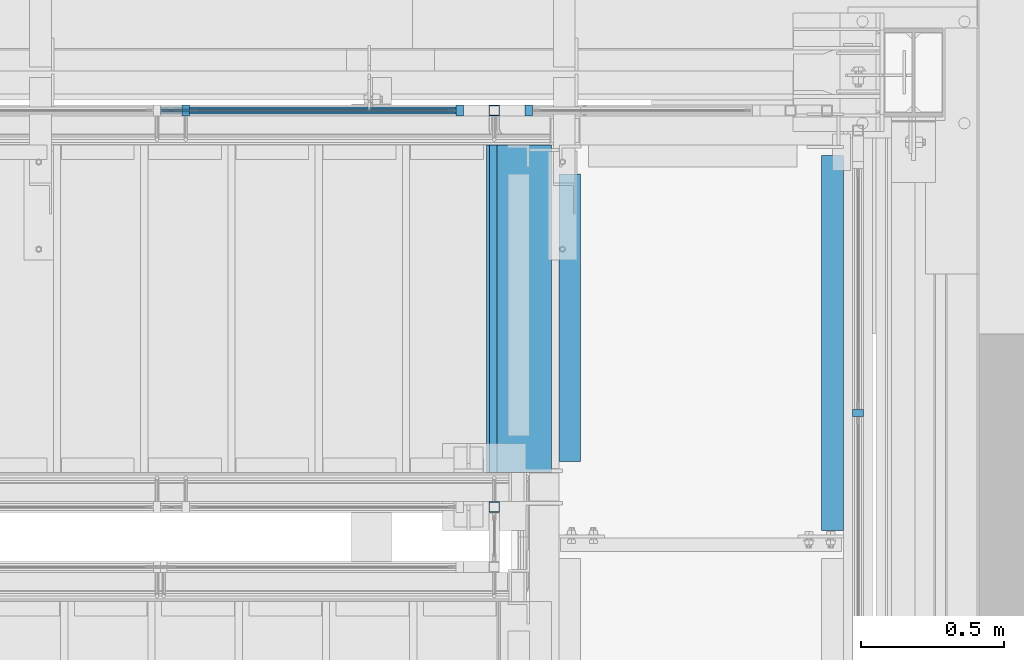
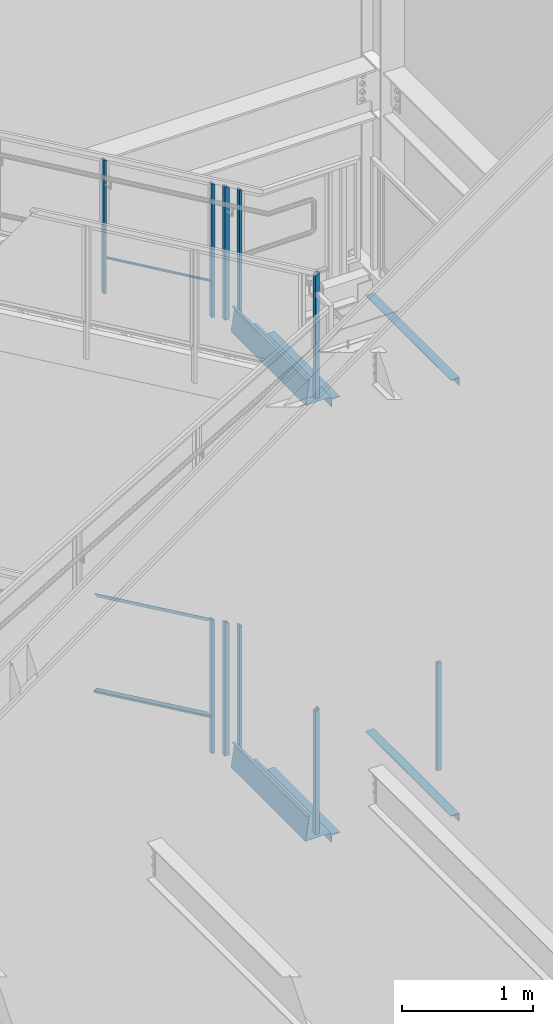
# One storey, part 799 of 1179: 12 members, 8 beams, 11 elements without a shape of their own.
"""IFC2X3 building model written with IfcOpenShell, lengths in millimetres."""

import ifcopenshell
import ifcopenshell.guid

model = None  # the IFC model being written
_history = None  # IfcOwnerHistory: only IFC2X3 demands one
_inside = {}  # id of a spatial element -> (the spatial element, [elements in it])
_under = {}  # id of a project, library or spatial element -> (it, [spatial elements below it])
_declared = {}  # id of a project -> (the project, [libraries it declares])
_typed = {}  # id of a type object -> (the type object, [elements of that type])
_made_of = {}  # id of a material, layer set ... -> (it, [elements and type objects made of it])


def new_model(schema):
    """Start an empty IFC model of exactly this schema.

    Asked for "IFC4X3", IfcOpenShell would pick the latest addendum, in which some entities
    have other attributes; the version numbers below select the first issue.
    IFC2X3 requires an IfcOwnerHistory on every rooted entity: one is made here for all.
    """
    global model, _history
    if schema == "IFC4X3":
        model = ifcopenshell.file(schema_version=(4, 3, 0, 0))
    else:
        model = ifcopenshell.file(schema=schema)
    _inside.clear()
    _under.clear()
    _declared.clear()
    _typed.clear()
    _made_of.clear()
    _history = None
    if model.schema == "IFC2X3":
        org = make("IfcOrganization", Name="unknown")
        user = make(
            "IfcPersonAndOrganization",
            ThePerson=make("IfcPerson", FamilyName="unknown"),
            TheOrganization=org,
        )
        app = make(
            "IfcApplication",
            ApplicationDeveloper=org,
            Version="unknown",
            ApplicationFullName="unknown",
            ApplicationIdentifier="unknown",
        )
        _history = make(
            "IfcOwnerHistory",
            OwningUser=user,
            OwningApplication=app,
            ChangeAction="ADDED",
            CreationDate=0,
        )
    return model


def make(cls, **values):
    """One entity of the class cls with the attributes given. An attribute that is None is left unset."""
    return model.create_entity(
        cls, **{name: value for name, value in values.items() if value is not None}
    )


def rooted(cls, **values):
    """An entity with a GlobalId (a new one), such as an element, a storey or a relation."""
    return make(cls, GlobalId=ifcopenshell.guid.new(), OwnerHistory=_history, **values)


def si_unit(unit_type, name, prefix=None):
    """IfcSIUnit, for example si_unit("LENGTHUNIT", "METRE", prefix="MILLI")."""
    return make("IfcSIUnit", UnitType=unit_type, Prefix=prefix, Name=name)


def assignment(units):
    """IfcUnitAssignment: the units of a project."""
    return None if units is None else make("IfcUnitAssignment", Units=units)


def point(xyz):
    """IfcCartesianPoint."""
    return None if xyz is None else make("IfcCartesianPoint", Coordinates=xyz)


def direction(xyz):
    """IfcDirection."""
    return None if xyz is None else make("IfcDirection", DirectionRatios=xyz)


def frame(location, z_axis=None, x_axis=None):
    """IfcAxis2Placement3D, a coordinate frame: its origin and axes. An axis left out is left unset."""
    return make(
        "IfcAxis2Placement3D",
        Location=point(location),
        Axis=direction(z_axis),
        RefDirection=direction(x_axis),
    )


def origin_with_axes():
    """The frame at (0, 0, 0) with the z axis (0, 0, 1) and the x axis (1, 0, 0) written out."""
    return frame((0.0, 0.0, 0.0), z_axis=(0.0, 0.0, 1.0), x_axis=(1.0, 0.0, 0.0))


def place(relative_to, where):
    """IfcLocalPlacement: puts the frame where relative to a parent placement (None: the world)."""
    return make(
        "IfcLocalPlacement", PlacementRelTo=relative_to, RelativePlacement=where
    )


def context(
    kind, dimensions, precision=None, world=None, true_north=None, identifier=None
):
    """IfcGeometricRepresentationContext, for example the 3D "Model" context."""
    return make(
        "IfcGeometricRepresentationContext",
        ContextIdentifier=identifier,
        ContextType=kind,
        CoordinateSpaceDimension=dimensions,
        Precision=precision,
        WorldCoordinateSystem=world,
        TrueNorth=true_north,
    )


def subcontext(parent, identifier, kind, view, scale=None):
    """IfcGeometricRepresentationSubContext, for example "Body" below "Model"."""
    return make(
        "IfcGeometricRepresentationSubContext",
        ContextIdentifier=identifier,
        ContextType=kind,
        ParentContext=parent,
        TargetScale=scale,
        TargetView=view,
    )


def project(units=None, contexts=None):
    """IfcProject with its units and contexts."""
    return rooted(
        "IfcProject",
        Name="project",
        RepresentationContexts=contexts,
        UnitsInContext=assignment(units),
    )


def spatial(cls, under=None, at=None, **own):
    """A site, building, storey or space (cls), placed at a placement, below another one or the project."""
    s = rooted(cls, ObjectPlacement=at, **own)
    if under is not None:
        _under.setdefault(under.id(), (under, []))[1].append(s)
    return s


def faces_of(points, faces, orient=None, outer=None):
    """IfcFace entities. A face is a list of loops; a loop is a list of indices into points, from 0.

    orient and outer hold one flag for each loop. By default every Orientation is true, the
    first loop of a face is its IfcFaceOuterBound and the others are IfcFaceBound.
    """
    made = []
    for i, loops in enumerate(faces):
        bounds = []
        for j, loop in enumerate(loops):
            is_outer = j == 0 if outer is None else outer[i][j]
            bounds.append(
                make(
                    "IfcFaceOuterBound" if is_outer else "IfcFaceBound",
                    Bound=make("IfcPolyLoop", Polygon=[points[k] for k in loop]),
                    Orientation=True if orient is None else orient[i][j],
                )
            )
        made.append(make("IfcFace", Bounds=bounds))
    return made


def faceted_brep(points, faces, orient=None, outer=None, voids=None):
    """IfcFacetedBrep: a solid bounded by flat faces; with voids (closed shells), ...WithVoids."""
    shared = [point(p) for p in points]
    hull = make("IfcClosedShell", CfsFaces=faces_of(shared, faces, orient, outer))
    if voids is None:
        return make("IfcFacetedBrep", Outer=hull)
    return make(
        "IfcFacetedBrepWithVoids",
        Outer=hull,
        Voids=[
            make(cls, CfsFaces=faces_of(shared, fs, o, b)) for cls, fs, o, b in voids
        ],
    )


def shape(context_of_items, identifier, shape_type, items):
    """IfcShapeRepresentation: the items that make up one representation, for example the "Body"."""
    return make(
        "IfcShapeRepresentation",
        ContextOfItems=context_of_items,
        RepresentationIdentifier=identifier,
        RepresentationType=shape_type,
        Items=items,
    )


def material(Name=None, Category=None):
    """IfcMaterial."""
    return make("IfcMaterial", Name=Name, Category=Category)


def made_of(thing, what):
    """Note that an element or type object is made of a material, layer set ...; save() writes the relation."""
    if what is not None:
        _made_of.setdefault(what.id(), (what, []))[1].append(thing)
    return thing


def type_object(cls, material=None, **own):
    """A type object (cls), such as IfcWallType, which elements share."""
    return made_of(rooted(cls, **own), material)


def element(
    cls,
    number,
    at=None,
    inside=None,
    cuts=None,
    type_object=None,
    material=None,
    context=None,
    identifier="Body",
    shape_type=None,
    held_by="IfcProductDefinitionShape",
    body=None,
    shapes=None,
    **own,
):
    """One element of the class cls, such as IfcWall. Its Tag is "e" and its number.

    at: its placement. inside: the storey or other place that contains it. cuts: it is an
    opening in that element (IfcRelVoidsElement). A single representation is given by context,
    identifier, shape_type and body (its items); several are given by shapes. held_by: the class
    of the entity that holds the representations. save() writes the other relations.
    """
    e = rooted(cls, Tag="e%d" % number, ObjectPlacement=at, **own)
    if body is not None:
        shapes = [shape(context, identifier, shape_type, body)]
    if shapes is not None:
        e.Representation = make(held_by, Representations=shapes)
    if inside is not None:
        _inside.setdefault(inside.id(), (inside, []))[1].append(e)
    if cuts is not None:
        rooted(
            "IfcRelVoidsElement", RelatingBuildingElement=cuts, RelatedOpeningElement=e
        )
    if type_object is not None:
        _typed.setdefault(type_object.id(), (type_object, []))[1].append(e)
    return made_of(e, material)


def aggregate(whole, parts):
    """IfcRelAggregates: a whole, such as a stair, and the parts it consists of."""
    return rooted("IfcRelAggregates", RelatingObject=whole, RelatedObjects=parts)


def save(model, path):
    """Write the relations noted so far, then the file.

    IfcRelAggregates (storeys below a building ...), IfcRelContainedInSpatialStructure (elements
    in a storey), IfcRelDefinesByType, IfcRelAssociatesMaterial and IfcRelDeclares: one each for
    every whole, place, type object, material and project.
    """
    for whole, parts in _under.values():
        aggregate(whole, parts)
    for where, things in _inside.values():
        rooted(
            "IfcRelContainedInSpatialStructure",
            RelatedElements=things,
            RelatingStructure=where,
        )
    for kind, things in _typed.values():
        rooted("IfcRelDefinesByType", RelatedObjects=things, RelatingType=kind)
    for what, things in _made_of.values():
        rooted("IfcRelAssociatesMaterial", RelatedObjects=things, RelatingMaterial=what)
    for by, libraries in _declared.values():
        rooted("IfcRelDeclares", RelatingContext=by, RelatedDefinitions=libraries)
    model.write(path)


model = new_model("IFC2X3")

# Units and contexts
model_context = context("Model", 3, precision=1e-05, world=origin_with_axes())
body_context = subcontext(model_context, "Body", "Model", "MODEL_VIEW")
ifc_project = project(units=[si_unit("LENGTHUNIT", "METRE", prefix="MILLI"), si_unit("AREAUNIT", "SQUARE_METRE"), si_unit("VOLUMEUNIT", "CUBIC_METRE"), si_unit("MASSUNIT", "GRAM", prefix="KILO"), si_unit("TIMEUNIT", "SECOND"), si_unit("PLANEANGLEUNIT", "RADIAN"), si_unit("SOLIDANGLEUNIT", "STERADIAN"), si_unit("THERMODYNAMICTEMPERATUREUNIT", "DEGREE_CELSIUS"), si_unit("LUMINOUSINTENSITYUNIT", "LUMEN")], contexts=[model_context])

# Site, building, storey
site_placement = place(None, origin_with_axes())
site = spatial("IfcSite", under=ifc_project, at=site_placement, CompositionType="ELEMENT")
building_placement = place(site_placement, origin_with_axes())
building = spatial("IfcBuilding", under=site, at=building_placement, Name="Undefined", CompositionType="ELEMENT")
storey_placement = place(building_placement, origin_with_axes())
storey = spatial("IfcBuildingStorey", under=building, at=storey_placement, Name="Undefined", CompositionType="ELEMENT", Elevation=0.0)

# Assembly, members
assembly_1_placement = place(storey_placement, origin_with_axes())
assembly_1 = element("IfcElementAssembly", 1, at=assembly_1_placement, inside=storey, Name="GUARDRAIL", AssemblyPlace="NOTDEFINED", PredefinedType="RIGID_FRAME")
ifc_material_1 = material(Name="STEEL/A36")
member_type_1 = type_object("IfcMemberType", PredefinedType="NOTDEFINED")
member_1_placement = place(assembly_1_placement, frame((22964.7750009048, 41065.449999238, 6098.38737109697), z_axis=(0.0, -1.0, 0.0), x_axis=(0.0, 0.0, 1.0)))
member_1 = element("IfcMember", 2, at=member_1_placement, type_object=member_type_1, material=ifc_material_1, Name="POST", context=body_context, shape_type="Brep", body=[
    faceted_brep([(0.0, 12.7000000000007, -19.0500000000029), (0.0, 12.7000000000007, 19.0500000000029), (1257.9937907086, 12.7000000000007, 19.0500000000029), (1257.9937907086, 12.7000000000007, -19.0500000000029), (0.0, -12.7000000000007, 19.0500000000029), (1243.17712405909, -12.7000000000007, 19.0500000000029), (0.0, -12.7000000000007, -19.0500000000029), (1243.17712405909, -12.7000000000007, -19.0500000000029)], [[[0, 1, 2, 3]], [[1, 4, 5, 2]], [[4, 6, 7, 5]], [[6, 0, 3, 7]], [[5, 7, 3, 2]], [[6, 4, 1, 0]]]),
])
member_2_placement = place(assembly_1_placement, frame((22723.4750009048, 41065.449999238, 6239.1457045467), z_axis=(0.0, -1.0, 0.0), x_axis=(0.0, 0.0, 1.0)))
member_2 = element("IfcMember", 3, at=member_2_placement, type_object=member_type_1, material=ifc_material_1, Name="POST", context=body_context, shape_type="Brep", body=[
    faceted_brep([(0.0, 12.7000000000007, -19.0500000000029), (0.0, 12.7000000000007, 19.0500000000029), (1257.9937907086, 12.7000000000007, 19.0500000000029), (1257.9937907086, 12.7000000000007, -19.0500000000029), (0.0, -12.7000000000007, 19.0500000000029), (1243.17712405909, -12.7000000000007, 19.0500000000029), (0.0, -12.7000000000007, -19.0500000000029), (1243.17712405909, -12.7000000000007, -19.0500000000029)], [[[0, 1, 2, 3]], [[1, 4, 5, 2]], [[4, 6, 7, 5]], [[6, 0, 3, 7]], [[5, 7, 3, 2]], [[6, 4, 1, 0]]]),
])
member_3_placement = place(assembly_1_placement, frame((21766.7416677555, 41065.449999238, 6797.2401493453), z_axis=(0.0, -1.0, 0.0), x_axis=(0.0, 0.0, 1.0)))
member_3 = element("IfcMember", 4, at=member_3_placement, type_object=member_type_1, material=ifc_material_1, Name="POST", context=body_context, shape_type="Brep", body=[
    faceted_brep([(0.0, 12.7000000000007, -19.0500000000029), (0.0, 12.7000000000007, 19.0500000000029), (1257.9937907086, 12.7000000000007, 19.0500000000029), (1257.9937907086, 12.7000000000007, -19.0500000000029), (0.0, -12.7000000000007, 19.0500000000029), (1243.17712405909, -12.7000000000007, 19.0500000000029), (0.0, -12.7000000000007, -19.0500000000029), (1243.17712405909, -12.7000000000007, -19.0500000000029)], [[[0, 1, 2, 3]], [[1, 4, 5, 2]], [[4, 6, 7, 5]], [[6, 0, 3, 7]], [[5, 7, 3, 2]], [[6, 4, 1, 0]]]),
])

assembly_2_placement = place(storey_placement, origin_with_axes())
assembly_2 = element("IfcElementAssembly", 5, at=assembly_2_placement, inside=storey, Name="GUARDRAIL", AssemblyPlace="NOTDEFINED", PredefinedType="RIGID_FRAME")
member_4_placement = place(assembly_2_placement, frame((22964.7748872972, 41065.4499993604, 2024.409589174), z_axis=(0.0, -1.0, 0.0), x_axis=(0.0, 0.0, 1.0)))
member_4 = element("IfcMember", 6, at=member_4_placement, type_object=member_type_1, material=ifc_material_1, Name="POST", context=body_context, shape_type="Brep", body=[
    faceted_brep([(0.0, 12.7000000000007, -19.0500000000029), (0.0, 12.7000000000007, 19.0500000000029), (1257.59245944594, 12.7000000000007, 19.0500000000029), (1257.59245944594, 12.7000000000007, -19.0500000000029), (0.0, -12.7000000000007, 19.0500000000029), (1242.88603583053, -12.7000000000007, 19.0500000000029), (0.0, -12.7000000000007, -19.0500000000029), (1242.88603583053, -12.7000000000007, -19.0500000000029)], [[[0, 1, 2, 3]], [[1, 4, 5, 2]], [[4, 6, 7, 5]], [[6, 0, 3, 7]], [[5, 7, 3, 2]], [[6, 4, 1, 0]]]),
])
member_5_placement = place(assembly_2_placement, frame((22723.4748880622, 41065.4499993604, 2164.12061307754), z_axis=(0.0, -1.0, 0.0), x_axis=(0.0, 0.0, 1.0)))
member_5 = element("IfcMember", 7, at=member_5_placement, type_object=member_type_1, material=ifc_material_1, Name="POST", context=body_context, shape_type="Brep", body=[
    faceted_brep([(0.0, 12.7000000000007, -19.0500000000029), (0.0, 12.7000000000007, 19.0500000000029), (1257.59245944594, 12.7000000000007, 19.0500000000029), (1257.59245944594, 12.7000000000007, -19.0500000000029), (0.0, -12.7000000000007, 19.0500000000029), (1242.88603583053, -12.7000000000007, 19.0500000000029), (0.0, -12.7000000000007, -19.0500000000029), (1242.88603583053, -12.7000000000007, -19.0500000000029)], [[[0, 1, 2, 3]], [[1, 4, 5, 2]], [[4, 6, 7, 5]], [[6, 0, 3, 7]], [[5, 7, 3, 2]], [[6, 4, 1, 0]]]),
])

# Assembly, member
assembly_3_placement = place(storey_placement, origin_with_axes())
assembly_3 = element("IfcElementAssembly", 8, at=assembly_3_placement, inside=storey, Name="GUARDRAIL", AssemblyPlace="NOTDEFINED", PredefinedType="RIGID_FRAME")
member_6_placement = place(assembly_3_placement, frame((24114.1250004143, 40009.2333333341, 2155.82499903482), z_axis=(-1.0, 0.0, 0.0), x_axis=(0.0, 0.0, 1.0)))
member_6 = element("IfcMember", 9, at=member_6_placement, type_object=member_type_1, material=ifc_material_1, Name="POST", context=body_context, shape_type="Brep", body=[
    faceted_brep([(0.0, 12.7000000000007, -19.0500000000029), (0.0, 12.7000000000007, 19.0500000000029), (1009.65000040151, 12.6999999999971, 19.0499999999993), (1009.65000040151, 12.6999999999971, -19.0499999999993), (0.0, -12.7000000000007, 19.0500000000029), (1009.65000040151, -12.6999999999971, 19.0499999999993), (0.0, -12.7000000000007, -19.0500000000029), (1009.65000040151, -12.6999999999971, -19.0499999999993)], [[[0, 1, 2, 3]], [[1, 4, 5, 2]], [[4, 6, 7, 5]], [[6, 0, 3, 7]], [[5, 7, 3, 2]], [[6, 4, 1, 0]]]),
])
aggregate(assembly_3, [member_6])

# Beam
ifc_material_2 = material(Name="STEEL/BUY-OUT")
beam_type_1 = type_object("IfcBeamType", PredefinedType="NOTDEFINED")
beam_1_placement = place(assembly_2_placement, frame((22207.4122472657, 41062.2751647691, 2831.43122798005), z_axis=(0.86540914081268, 0.0, -0.501065882891521), x_axis=(-0.501065882891527, 0.0, -0.865409140812677)))
beam_1 = element("IfcBeam", 10, at=beam_1_placement, type_object=beam_type_1, material=ifc_material_2, Name="U-EDGE", context=body_context, shape_type="Brep", body=[
    faceted_brep([(-2.17914930544794e-09, 1.58750000000146, -579.8750616161), (-2.17914930544794e-09, -1.58750000000146, -579.8750616161), (2.06819095183164e-09, -1.58750000000146, 550.462303003866), (2.06819095183164e-09, 1.58750000000146, 550.462303003866), (22.2250000220702, 1.58750000000146, -592.688577145202), (22.225000051898, 1.58750000000146, 589.01191290709), (22.225000034794, 4.76249998386629, -592.688577152541), (22.2250000392505, 4.7625000160333, 589.011912885151), (7.50696926843375e-08, 4.76249998754065, -579.875061660634), (7.28450686438009e-08, 4.7625000118278, 550.462303126626), (7.50696926843375e-08, 7.93749998753628, -579.875061660634), (7.28450686438009e-08, 7.93750001182343, 550.462303126626), (25.4000000347896, 7.93749998381099, -594.518999999977), (25.4000000343149, 7.9375, 594.519), (25.4000000220258, -1.58750000000146, -594.518999999807), (25.4000000343149, -1.58750000000146, 594.519)], [[[0, 1, 2, 3]], [[4, 0, 3, 5]], [[6, 4, 5, 7]], [[8, 6, 7, 9]], [[10, 8, 9, 11]], [[12, 10, 11, 13]], [[14, 12, 13, 15]], [[11, 9, 7, 5, 3, 2, 15, 13]], [[1, 14, 15, 2]], [[0, 4, 6, 8, 10, 12, 14, 1]]]),
])

beam_2_placement = place(assembly_2_placement, frame((22181.9581376491, 41062.2751647691, 3697.10650203671), z_axis=(0.86540914081268, 0.0, -0.501065882891521), x_axis=(0.501065882891522, 0.0, 0.865409140812679)))
beam_2 = element("IfcBeam", 11, at=beam_2_placement, type_object=beam_type_1, material=ifc_material_2, Name="U-EDGE", context=body_context, shape_type="Brep", body=[
    faceted_brep([(-5.08043740410358e-09, -4.76250001176231, -550.462297073285), (-5.08043740410358e-09, -7.93750001176522, -550.462297073285), (2.06819095183164e-09, -7.93749998760177, 579.875144306196), (2.06819095183164e-09, -4.76249998760613, 579.875144306196), (22.2249999989635, -4.76250001590233, -589.011912123857), (22.2249999997566, -4.76249998399726, 592.68851804268), (22.2250000115582, -1.58750000000146, -589.011912145696), (22.2249999870892, -1.58750000000146, 592.68851803538), (-3.47426976077259e-10, -1.58750000000146, -550.462297081494), (3.69254848919809e-10, -1.58750000000146, 579.875144305217), (-3.47426976077259e-10, 1.58750000000146, -550.462297081494), (3.69254848919809e-10, 1.58750000000146, 579.875144305217), (25.4000001784334, 1.58750000000146, -594.51900000087), (25.3999999489688, 1.58750000000146, 594.519), (25.4000002532193, -7.93749990531796, -594.51900000187), (25.3999999489688, -7.9375, 594.519)], [[[0, 1, 2, 3]], [[4, 0, 3, 5]], [[6, 4, 5, 7]], [[8, 6, 7, 9]], [[10, 8, 9, 11]], [[12, 10, 11, 13]], [[14, 12, 13, 15]], [[11, 9, 7, 5, 3, 2, 15, 13]], [[1, 14, 15, 2]], [[0, 4, 6, 8, 10, 12, 14, 1]]]),
])

# Member
ifc_material_3 = material()
member_type_2 = type_object("IfcMemberType", Name="HSS1-1/2X1-1/2X1/8", PredefinedType="NOTDEFINED")
member_7_placement = place(assembly_1_placement, frame((22844.1250009048, 41065.449999238, 6168.76653782184), z_axis=(-1.0, 0.0, 0.0), x_axis=(0.0, 0.0, 1.0)))
member_7 = element("IfcMember", 12, at=member_7_placement, type_object=member_type_2, material=ifc_material_3, Name="POST", ObjectType="HSS1-1/2X1-1/2X1/8", context=body_context, shape_type="Brep", body=[
    faceted_brep([(6.35000000000014, 15.874999282998, -15.8749992830017), (6.35000000000014, -15.874999282998, -15.8749992830017), (1241.32504350118, -15.874999282998, -15.8749992830017), (1241.32504350118, 15.874999282998, -15.8749992830017), (6.35000000000014, -15.874999282998, 15.8749992830017), (1259.84587597657, -15.874999282998, 15.8749992830017), (6.35000000000014, 15.874999282998, 15.8749992830017), (1259.84587597657, 15.874999282998, 15.8749992830017), (6.35000000000014, 19.0499992350015, -19.0499992350015), (6.35000000000014, 19.0499992350015, 19.0499992350015), (1261.69795927976, 19.0499992350015, 19.0499992350015), (1239.47296019799, 19.0499992350015, -19.0499992350015), (6.35000000000014, -19.0499992350015, 19.0499992350015), (1261.69795927976, -19.0499992350015, 19.0499992350015), (6.35000000000014, -19.0499992350015, -19.0499992350015), (1239.47296019799, -19.0499992350015, -19.0499992350015)], [[[0, 1, 2, 3]], [[1, 4, 5, 2]], [[4, 6, 7, 5]], [[6, 0, 3, 7]], [[8, 9, 10, 11]], [[9, 12, 13, 10]], [[12, 14, 15, 13]], [[14, 8, 11, 15]], [[13, 15, 11, 10], [5, 7, 3, 2]], [[14, 12, 9, 8], [6, 4, 1, 0]]]),
])

member_8_placement = place(assembly_2_placement, frame((22844.1248872972, 41065.4499993604, 2094.26510134723), z_axis=(-1.0, 0.0, 0.0), x_axis=(0.0, 0.0, 1.0)))
member_8 = element("IfcMember", 13, at=member_8_placement, type_object=member_type_2, material=ifc_material_3, Name="POST", ObjectType="HSS1-1/2X1-1/2X1/8", context=body_context, shape_type="Brep", body=[
    faceted_brep([(6.35000000000014, 15.874999282998, -15.8749992830017), (6.35000000000014, -15.874999282998, -15.8749992830017), (1241.04773329657, -15.874999282998, -15.8749992830017), (1241.04773329657, 15.874999282998, -15.8749992830017), (6.35000000000014, -15.874999282998, 15.8749992830017), (1259.43076198557, -15.874999282998, 15.8749992830017), (6.35000000000014, 15.874999282998, 15.8749992830017), (1259.43076198557, 15.874999282998, 15.8749992830017), (6.35000000000014, 19.0499992350015, -19.0499992350015), (6.35000000000014, 19.0499992350015, 19.0499992350015), (1261.2690649097, 19.0499992350015, 19.0499992350015), (1239.20943037244, 19.0499992350015, -19.0499992350015), (6.35000000000014, -19.0499992350015, 19.0499992350015), (1261.2690649097, -19.0499992350015, 19.0499992350015), (6.35000000000014, -19.0499992350015, -19.0499992350015), (1239.20943037244, -19.0499992350015, -19.0499992350015)], [[[0, 1, 2, 3]], [[1, 4, 5, 2]], [[4, 6, 7, 5]], [[6, 0, 3, 7]], [[8, 9, 10, 11]], [[9, 12, 13, 10]], [[12, 14, 15, 13]], [[14, 8, 11, 15]], [[13, 15, 11, 10], [5, 7, 3, 2]], [[14, 12, 9, 8], [6, 4, 1, 0]]]),
])

# Assembly, member
assembly_4_placement = place(storey_placement, origin_with_axes())
assembly_4 = element("IfcElementAssembly", 14, at=assembly_4_placement, inside=storey, Name="GUARDRAIL", AssemblyPlace="NOTDEFINED", PredefinedType="RIGID_FRAME")
member_9_placement = place(assembly_4_placement, frame((22844.1250009048, 39681.1500007796, 6275.74561220699), z_axis=(-1.0, 0.0, 0.0), x_axis=(0.0, 0.0, 1.0)))
member_9 = element("IfcMember", 15, at=member_9_placement, type_object=member_type_2, material=ifc_material_3, Name="POST", ObjectType="HSS1-1/2X1-1/2X1/8", context=body_context, shape_type="Brep", body=[
    faceted_brep([(6.35000000000014, 15.874999282998, -15.8749992830017), (6.35000000000014, -15.874999282998, -15.8749992830017), (1174.77876794096, -15.874999282998, -15.8749992830017), (1174.77876794096, 15.874999282998, -15.8749992830017), (6.35000000000014, -15.874999282998, 15.8749992830017), (1156.54251067731, -15.874999282998, 15.8749992830017), (6.35000000000014, 15.874999282998, 15.8749992830017), (1156.54251067731, 15.874999282998, 15.8749992830017), (6.35000000000014, 19.0499992350015, -19.0499992350015), (6.35000000000014, 19.0499992350015, 19.0499992350015), (1154.71888489615, 19.0499992350015, 19.0499992350015), (1176.60239372212, 19.0499992350015, -19.0499992350015), (6.35000000000014, -19.0499992350015, 19.0499992350015), (1154.71888489615, -19.0499992350015, 19.0499992350015), (6.35000000000014, -19.0499992350015, -19.0499992350015), (1176.60239372212, -19.0499992350015, -19.0499992350015)], [[[0, 1, 2, 3]], [[1, 4, 5, 2]], [[4, 6, 7, 5]], [[6, 0, 3, 7]], [[8, 9, 10, 11]], [[9, 12, 13, 10]], [[12, 14, 15, 13]], [[14, 8, 11, 15]], [[13, 15, 11, 10], [5, 7, 3, 2]], [[14, 12, 9, 8], [6, 4, 1, 0]]]),
])
aggregate(assembly_4, [member_9])

assembly_5_placement = place(storey_placement, origin_with_axes())
assembly_5 = element("IfcElementAssembly", 16, at=assembly_5_placement, inside=storey, Name="GUARDRAIL", AssemblyPlace="NOTDEFINED", PredefinedType="RIGID_FRAME")
member_10_placement = place(assembly_5_placement, frame((22844.1248872972, 39681.150000778, 2202.22061306289), z_axis=(-1.0, 0.0, 0.0), x_axis=(0.0, 0.0, 1.0)))
member_10 = element("IfcMember", 17, at=member_10_placement, type_object=member_type_2, material=ifc_material_3, Name="POST", ObjectType="HSS1-1/2X1-1/2X1/8", context=body_context, shape_type="Brep", body=[
    faceted_brep([(6.35000000000014, 15.874999282998, -15.8749992830017), (6.35000000000014, -15.874999282998, -15.8749992830017), (1173.44885345168, -15.874999282998, -15.8749992830017), (1173.44885345168, 15.874999282998, -15.8749992830017), (6.35000000000014, -15.874999282998, 15.8749992830017), (1155.14403466819, -15.874999282998, 15.8749992830017), (6.35000000000014, 15.874999282998, 15.8749992830017), (1155.14403466819, 15.874999282998, 15.8749992830017), (6.35000000000014, 19.0499992350015, -19.0499992350015), (6.35000000000014, 19.0499992350015, 19.0499992350015), (1153.31355273484, 19.0499992350015, 19.0499992350015), (1175.27933538503, 19.0499992350015, -19.0499992350015), (6.35000000000014, -19.0499992350015, 19.0499992350015), (1153.31355273484, -19.0499992350015, 19.0499992350015), (6.35000000000014, -19.0499992350015, -19.0499992350015), (1175.27933538503, -19.0499992350015, -19.0499992350015)], [[[0, 1, 2, 3]], [[1, 4, 5, 2]], [[4, 6, 7, 5]], [[6, 0, 3, 7]], [[8, 9, 10, 11]], [[9, 12, 13, 10]], [[12, 14, 15, 13]], [[14, 8, 11, 15]], [[13, 15, 11, 10], [5, 7, 3, 2]], [[14, 12, 9, 8], [6, 4, 1, 0]]]),
])
aggregate(assembly_5, [member_10])

# Member
member_type_3 = type_object("IfcMemberType", PredefinedType="NOTDEFINED")
member_11_placement = place(assembly_1_placement, frame((21766.7416677555, 41065.4499992401, 7128.05397191716), z_axis=(0.0, -1.0, 0.0), x_axis=(0.863778851027978, 0.0, -0.503871111016285)))
member_11 = element("IfcMember", 18, at=member_11_placement, type_object=member_type_3, material=ifc_material_1, Name="BOTTOM_RAIL", context=body_context, shape_type="Brep", body=[
    faceted_brep([(10.9986698874163, 6.34999999999854, -12.6999999999971), (10.9986698874163, 6.34999999999854, 12.6999999999971), (1089.20668431148, 6.35000000024229, 12.6999999999971), (1089.20668431148, 6.35000000024229, -12.6999999999971), (18.4070032121654, -6.34999999999127, 12.6999999999971), (1096.61501763624, -6.34999999974752, 12.6999999999971), (18.4070032121654, -6.34999999999127, -12.6999999999971), (1096.61501763624, -6.34999999974752, -12.6999999999971)], [[[0, 1, 2, 3]], [[1, 4, 5, 2]], [[4, 6, 7, 5]], [[6, 0, 3, 7]], [[5, 7, 3, 2]], [[6, 4, 1, 0]]]),
])

aggregate(assembly_1, [member_1, member_2, member_11, member_7, member_3])

member_12_placement = place(assembly_2_placement, frame((21666.1999246046, 41065.4499993604, 3106.46611713066), z_axis=(0.0, -1.0, 0.0), x_axis=(0.86540914081268, 0.0, -0.501065882891521)))
member_12 = element("IfcMember", 19, at=member_12_placement, type_object=member_type_3, material=ifc_material_1, Name="BOTTOM_RAIL", context=body_context, shape_type="Brep", body=[
    faceted_brep([(10.998533752896, 6.34999999999854, -12.6999999999971), (10.998533752896, 6.34999999999854, 12.6999999999971), (1203.35358848741, 6.35000000053878, 12.6999999999971), (1203.35358848741, 6.35000000053878, -12.6999999999971), (18.3517455606161, -6.34999999998945, 12.6999999999971), (1210.70680029513, -6.34999999944921, 12.6999999999971), (18.3517455606161, -6.34999999998945, -12.6999999999971), (1210.70680029513, -6.34999999944921, -12.6999999999971)], [[[0, 1, 2, 3]], [[1, 4, 5, 2]], [[4, 6, 7, 5]], [[6, 0, 3, 7]], [[5, 7, 3, 2]], [[6, 4, 1, 0]]]),
])

aggregate(assembly_2, [member_4, beam_1, beam_2, member_5, member_12, member_8])

# Assembly, beam
assembly_6_placement = place(storey_placement, origin_with_axes())
assembly_6 = element("IfcElementAssembly", 20, at=assembly_6_placement, inside=storey, Name="BEAM", AssemblyPlace="NOTDEFINED", PredefinedType="RIGID_FRAME")
beam_type_2 = type_object("IfcBeamType", Name="L3X3X1/4", PredefinedType="NOTDEFINED")
beam_3_placement = place(assembly_6_placement, frame((24025.225, 39598.996875, 6051.55), z_axis=(0.0, 0.0, -1.0), x_axis=(0.0, 1.0, 0.0)))
beam_3 = element("IfcBeam", 21, at=beam_3_placement, type_object=beam_type_2, material=ifc_material_1, Name="ANGLE", ObjectType="L3X3X1/4", context=body_context, shape_type="Brep", body=[
    faceted_brep([(0.0, 38.0999999999985, -38.0999999999999), (0.0, 38.0999999999985, 38.0999999999999), (1309.29062501167, 38.0999999999985, 38.1000000000004), (1309.29062501167, 38.0999999999985, -38.1000000000004), (0.0, 31.75, 38.1000000000004), (1309.29062501167, 31.75, 38.1000000000004), (0.0, 31.75, -31.75), (1309.29062501167, 31.75, -31.75), (0.0, -38.0999999999985, -31.75), (1309.29062501167, -38.0999999999985, -31.75), (0.0, -38.0999999999985, -38.0999999999999), (1309.29062501167, -38.0999999999985, -38.1000000000004)], [[[0, 1, 2, 3]], [[1, 4, 5, 2]], [[4, 6, 7, 5]], [[6, 8, 9, 7]], [[8, 10, 11, 9]], [[10, 0, 3, 11]], [[5, 7, 9, 11, 3, 2]], [[10, 8, 6, 4, 1, 0]]]),
])
aggregate(assembly_6, [beam_3])

assembly_7_placement = place(storey_placement, origin_with_axes())
assembly_7 = element("IfcElementAssembly", 22, at=assembly_7_placement, inside=storey, Name="BEAM", AssemblyPlace="NOTDEFINED", PredefinedType="RIGID_FRAME")
beam_4_placement = place(assembly_7_placement, frame((23107.6499999238, 39839.9000000055, 6051.55), z_axis=(1.0, 0.0, 0.0), x_axis=(0.0, 1.0, 0.0)))
beam_4 = element("IfcBeam", 23, at=beam_4_placement, type_object=beam_type_2, material=ifc_material_1, Name="ANGLE", ObjectType="L3X3X1/4", context=body_context, shape_type="Brep", body=[
    faceted_brep([(0.0, 38.0999999999985, -38.0999999999999), (0.0, 38.0999999999985, 38.0999999999999), (1003.29999999383, 38.1000000000004, 38.0999999999985), (1003.29999999383, 38.1000000000004, -38.0999999999985), (0.0, 31.75, 38.1000000000004), (1003.29999999383, 31.75, 38.0999999999985), (0.0, 31.75, -31.75), (1003.29999999383, 31.75, -31.75), (0.0, -38.0999999999985, -31.75), (1003.29999999383, -38.1000000000004, -31.75), (0.0, -38.0999999999985, -38.0999999999999), (1003.29999999383, -38.1000000000004, -38.0999999999985)], [[[0, 1, 2, 3]], [[1, 4, 5, 2]], [[4, 6, 7, 5]], [[6, 8, 9, 7]], [[8, 10, 11, 9]], [[10, 0, 3, 11]], [[5, 7, 9, 11, 3, 2]], [[10, 8, 6, 4, 1, 0]]]),
])
aggregate(assembly_7, [beam_4])

assembly_8_placement = place(storey_placement, origin_with_axes())
assembly_8 = element("IfcElementAssembly", 24, at=assembly_8_placement, inside=storey, Name="BEAM", AssemblyPlace="NOTDEFINED", PredefinedType="RIGID_FRAME")
beam_5_placement = place(assembly_8_placement, frame((24025.2250004143, 39598.996875, 1978.025), z_axis=(0.0, 0.0, -1.0), x_axis=(0.0, 1.0, 0.0)))
beam_5 = element("IfcBeam", 25, at=beam_5_placement, type_object=beam_type_2, material=ifc_material_1, Name="ANGLE", ObjectType="L3X3X1/4", context=body_context, shape_type="Brep", body=[
    faceted_brep([(0.0, 38.0999999999985, -38.0999999999999), (0.0, 38.0999999999985, 38.0999999999999), (1309.29062501167, 38.0999999999985, 38.1000000000004), (1309.29062501167, 38.0999999999985, -38.1000000000004), (0.0, 31.75, 38.1000000000004), (1309.29062501167, 31.75, 38.1000000000004), (0.0, 31.75, -31.75), (1309.29062501167, 31.75, -31.75), (0.0, -38.0999999999985, -31.75), (1309.29062501167, -38.0999999999985, -31.75), (0.0, -38.0999999999985, -38.0999999999999), (1309.29062501167, -38.0999999999985, -38.1000000000004)], [[[0, 1, 2, 3]], [[1, 4, 5, 2]], [[4, 6, 7, 5]], [[6, 8, 9, 7]], [[8, 10, 11, 9]], [[10, 0, 3, 11]], [[5, 7, 9, 11, 3, 2]], [[10, 8, 6, 4, 1, 0]]]),
])
aggregate(assembly_8, [beam_5])

assembly_9_placement = place(storey_placement, origin_with_axes())
assembly_9 = element("IfcElementAssembly", 26, at=assembly_9_placement, inside=storey, Name="BEAM", AssemblyPlace="NOTDEFINED", PredefinedType="RIGID_FRAME")
beam_6_placement = place(assembly_9_placement, frame((23107.6500003381, 39839.9000000405, 1978.025), z_axis=(1.0, 0.0, 0.0), x_axis=(0.0, 1.0, 0.0)))
beam_6 = element("IfcBeam", 27, at=beam_6_placement, type_object=beam_type_2, material=ifc_material_1, Name="ANGLE", ObjectType="L3X3X1/4", context=body_context, shape_type="Brep", body=[
    faceted_brep([(0.0, 38.0999999999985, -38.0999999999999), (0.0, 38.0999999999985, 38.0999999999999), (1003.29999999383, 38.1000000000004, 38.0999999999985), (1003.29999999383, 38.1000000000004, -38.0999999999985), (0.0, 31.75, 38.1000000000004), (1003.29999999383, 31.75, 38.0999999999985), (0.0, 31.75, -31.75), (1003.29999999383, 31.75, -31.75), (0.0, -38.0999999999985, -31.75), (1003.29999999383, -38.1000000000004, -31.75), (0.0, -38.0999999999985, -38.0999999999999), (1003.29999999383, -38.1000000000004, -38.0999999999985)], [[[0, 1, 2, 3]], [[1, 4, 5, 2]], [[4, 6, 7, 5]], [[6, 8, 9, 7]], [[8, 10, 11, 9]], [[10, 0, 3, 11]], [[5, 7, 9, 11, 3, 2]], [[10, 8, 6, 4, 1, 0]]]),
])
aggregate(assembly_9, [beam_6])

assembly_10_placement = place(storey_placement, origin_with_axes())
assembly_10 = element("IfcElementAssembly", 28, at=assembly_10_placement, inside=storey, Name="STAIR", AssemblyPlace="NOTDEFINED", PredefinedType="RIGID_FRAME")
beam_type_3 = type_object("IfcBeamType", PredefinedType="NOTDEFINED")
beam_7_placement = place(assembly_10_placement, frame((22828.2500002804, 40373.3000000029, 6367.76000000908), z_axis=(0.0, 1.0, 0.0), x_axis=(1.0, 0.0, 0.0)))
beam_7 = element("IfcBeam", 29, at=beam_7_placement, type_object=beam_type_3, material=ifc_material_1, Name="TREAD", context=body_context, shape_type="Brep", body=[
    faceted_brep([(0.0, -1.28999999999996, -571.5), (0.0, -1.28999999999996, 571.5), (0.0, 1.28999999999996, 571.5), (0.0, 1.28999999999996, -571.5), (22.4204843020925, 1.28999999997995, 571.5), (22.4204843020925, 1.28999999997995, -571.5), (25.4000000000015, -1.28999999999996, -571.5), (25.4000000000015, -1.28999999999996, 571.5), (-10.6051871266864, 229.89000000001, 571.5), (-10.6051871266864, 229.89000000001, -571.5), (-7.62567142878834, 227.310000000008, -571.5), (-7.62567142878834, 227.310000000008, 571.5), (215.899999999794, 229.889999999804, 571.5), (215.899999999794, 229.889999999804, -571.5), (215.899999999794, 227.309999999804, 571.5), (215.899999999794, 227.309999999804, -571.5)], [[[0, 1, 2, 3]], [[3, 2, 4, 5]], [[1, 0, 6, 7]], [[5, 4, 8, 9]], [[7, 6, 10, 11]], [[9, 8, 12, 13]], [[8, 4, 2, 1, 7, 11, 14, 12]], [[11, 10, 15, 14]], [[10, 6, 0, 3, 5, 9, 13, 15]], [[14, 15, 13, 12]]]),
])
aggregate(assembly_10, [beam_7])

assembly_11_placement = place(storey_placement, origin_with_axes())
assembly_11 = element("IfcElementAssembly", 30, at=assembly_11_placement, inside=storey, Name="STAIR", AssemblyPlace="NOTDEFINED", PredefinedType="RIGID_FRAME")
beam_type_4 = type_object("IfcBeamType", PredefinedType="NOTDEFINED")
beam_8_placement = place(assembly_11_placement, frame((22828.250000332, 40373.3000001154, 2292.91208328361), z_axis=(0.0, 1.0, 0.0), x_axis=(1.0, 0.0, 0.0)))
beam_8 = element("IfcBeam", 31, at=beam_8_placement, type_object=beam_type_4, material=ifc_material_1, Name="TREAD", context=body_context, shape_type="Brep", body=[
    faceted_brep([(0.0, -1.28999999999996, -571.5), (0.0, -1.28999999999996, 571.5), (0.0, 1.28999999999996, 571.5), (0.0, 1.28999999999996, -571.5), (22.4172599317753, 1.28999999998996, 571.5), (22.4172599317753, 1.28999999998996, -571.5), (25.4000000000015, -1.28999999999996, -571.5), (25.4000000000015, -1.28999999999996, 571.5), (-10.6560498227591, 228.500900000005, 571.5), (-10.6560498227591, 228.500900000005, -571.5), (-7.6733097545366, 225.920900000004, -571.5), (-7.6733097545366, 225.920900000004, 571.5), (215.899999999896, 228.500899999902, 571.5), (215.899999999896, 228.500899999902, -571.5), (215.899999999896, 225.920899999902, 571.5), (215.899999999896, 225.920899999902, -571.5)], [[[0, 1, 2, 3]], [[3, 2, 4, 5]], [[1, 0, 6, 7]], [[5, 4, 8, 9]], [[7, 6, 10, 11]], [[9, 8, 12, 13]], [[8, 4, 2, 1, 7, 11, 14, 12]], [[11, 10, 15, 14]], [[10, 6, 0, 3, 5, 9, 13, 15]], [[14, 15, 13, 12]]]),
])
aggregate(assembly_11, [beam_8])

save(model, "model.ifc")
